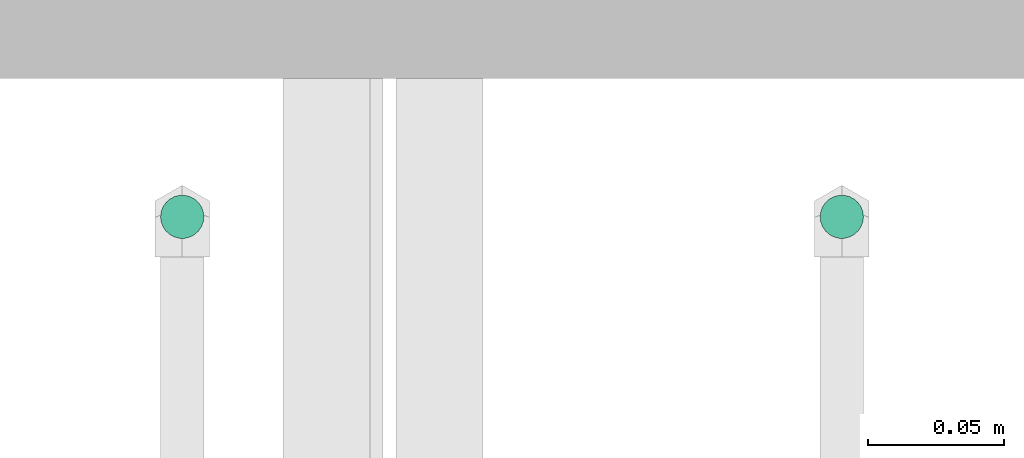
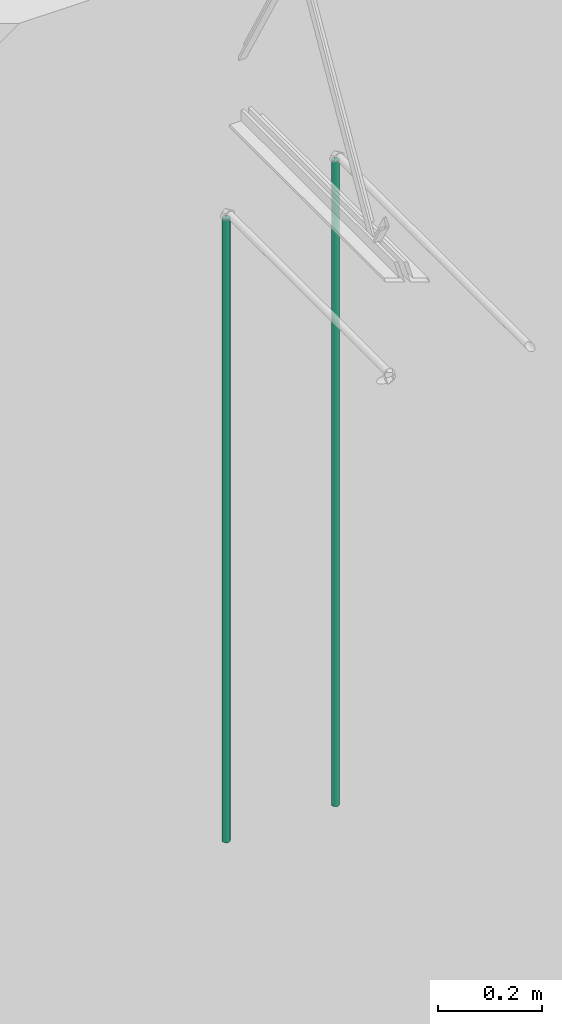
# One storey, part 9 of 31: 2 flow segments.
"""IFC2X3 building model written with IfcOpenShell, lengths in feet."""

from ifc_helpers import new_model, entity, si_unit, converted_unit, derived_unit, direction, frame, origin, origin_2d_with_axis, place, context, subcontext, project, spatial, circle, extrude, source, transform, mapped, type_object, type_shapes, element, save


model = new_model("IFC2X3")

# Units and contexts
model_context = context("Model", 3, precision=0.0001, world=origin(), true_north=direction((6.12303176911189e-17, 1.0)))
body_context = subcontext(model_context, "Body", "Model", "MODEL_VIEW")
ifc_project = project(units=[converted_unit("LENGTHUNIT", "FOOT", entity("IfcRatioMeasure", 0.3048), si_unit("LENGTHUNIT", "METRE"), dimensions=[1, 0, 0, 0, 0, 0, 0]), converted_unit("AREAUNIT", "SQUARE FOOT", entity("IfcRatioMeasure", 0.09290304), si_unit("AREAUNIT", "SQUARE_METRE"), dimensions=[2, 0, 0, 0, 0, 0, 0]), converted_unit("VOLUMEUNIT", "CUBIC FOOT", entity("IfcRatioMeasure", 0.028316846592), si_unit("VOLUMEUNIT", "CUBIC_METRE"), dimensions=[3, 0, 0, 0, 0, 0, 0]), converted_unit("PLANEANGLEUNIT", "DEGREE", entity("IfcRatioMeasure", 0.0174532925199433), si_unit("PLANEANGLEUNIT", "RADIAN"), dimensions=[0, 0, 0, 0, 0, 0, 0]), si_unit("MASSUNIT", "GRAM", prefix="KILO"), derived_unit("MASSDENSITYUNIT", [(si_unit("MASSUNIT", "GRAM", prefix="KILO"), 1), (si_unit("LENGTHUNIT", "METRE"), -3)]), si_unit("TIMEUNIT", "SECOND"), si_unit("FREQUENCYUNIT", "HERTZ"), si_unit("THERMODYNAMICTEMPERATUREUNIT", "DEGREE_CELSIUS"), derived_unit("THERMALTRANSMITTANCEUNIT", [(si_unit("MASSUNIT", "GRAM", prefix="KILO"), 1), (si_unit("THERMODYNAMICTEMPERATUREUNIT", "KELVIN"), -1), (si_unit("TIMEUNIT", "SECOND"), -3)]), derived_unit("VOLUMETRICFLOWRATEUNIT", [(si_unit("LENGTHUNIT", "METRE"), 3), (si_unit("TIMEUNIT", "SECOND"), -1)]), si_unit("ELECTRICCURRENTUNIT", "AMPERE"), si_unit("ELECTRICVOLTAGEUNIT", "VOLT"), si_unit("POWERUNIT", "WATT"), si_unit("FORCEUNIT", "NEWTON"), si_unit("ILLUMINANCEUNIT", "LUX"), si_unit("LUMINOUSFLUXUNIT", "LUMEN"), si_unit("LUMINOUSINTENSITYUNIT", "CANDELA"), derived_unit("USERDEFINED", [(si_unit("MASSUNIT", "GRAM", prefix="KILO"), -1), (si_unit("LENGTHUNIT", "METRE"), -2), (si_unit("TIMEUNIT", "SECOND"), 3), (si_unit("LUMINOUSFLUXUNIT", "LUMEN"), 1)]), derived_unit("LINEARVELOCITYUNIT", [(si_unit("LENGTHUNIT", "METRE"), 1), (si_unit("TIMEUNIT", "SECOND"), -1)]), si_unit("PRESSUREUNIT", "PASCAL"), derived_unit("USERDEFINED", [(si_unit("LENGTHUNIT", "METRE"), -2), (si_unit("MASSUNIT", "GRAM", prefix="KILO"), 1), (si_unit("TIMEUNIT", "SECOND"), -2)])], contexts=[model_context])

# Site, building, storey
site_placement = place(None, origin())
site = spatial("IfcSite", under=ifc_project, at=site_placement, CompositionType="ELEMENT")
building_placement = place(site_placement, origin())
building = spatial("IfcBuilding", under=site, at=building_placement, CompositionType="ELEMENT")
storey_placement = place(building_placement, frame((0.0, 0.0, 13.3333333333323)))
storey = spatial("IfcBuildingStorey", under=building, at=storey_placement, Name="Level 2", CompositionType="ELEMENT", Elevation=13.3333333333323)

# Flow segments
pipe_segment_type_1 = type_object("IfcPipeSegmentType", Name="Pipe Types:Standard", PredefinedType="NOTDEFINED")
shared_shape_1 = source(origin(), body_context, "Body", "SweptSolid", [
    extrude(circle(Radius=0.0260416666666667, at=origin_2d_with_axis()), frame((40.2660253422419, 6.09936739686864, 19.3333333333323), z_axis=(0.0, 0.0, 1.0), x_axis=(-1.0, 0.0, 0.0)), (0.0, 0.0, 1.0), 4.95166015625001),
])
type_shapes(pipe_segment_type_1, [shared_shape_1])
flow_segment_1_placement = place(building_placement, origin())
element("IfcFlowSegment", 1, at=flow_segment_1_placement, inside=storey, type_object=pipe_segment_type_1, Name="Pipe Types:Standard:Standard : Pipe Types:Standard", ObjectType="Standard : Pipe Types:Standard", context=body_context, shape_type="MappedRepresentation", body=[
    mapped(shared_shape_1, transform((0.0, 0.0, 0.0), scale=1.0)),
])
pipe_segment_type_2 = type_object("IfcPipeSegmentType", Name="Pipe Types:Standard", PredefinedType="NOTDEFINED")
shared_shape_2 = source(origin(), body_context, "Body", "SweptSolid", [
    extrude(circle(Radius=0.0260416666666667, at=origin_2d_with_axis()), frame((39.4724205095678, 6.09936739686864, 19.3333333333323), z_axis=(0.0, 0.0, 1.0), x_axis=(-1.0, 0.0, 0.0)), (0.0, 0.0, 1.0), 4.78499348958334),
])
type_shapes(pipe_segment_type_2, [shared_shape_2])
flow_segment_2_placement = place(building_placement, origin())
element("IfcFlowSegment", 2, at=flow_segment_2_placement, inside=storey, type_object=pipe_segment_type_2, Name="Pipe Types:Standard:Standard : Pipe Types:Standard", ObjectType="Standard : Pipe Types:Standard", context=body_context, shape_type="MappedRepresentation", body=[
    mapped(shared_shape_2, transform((0.0, 0.0, 0.0), scale=1.0)),
])

save(model, "model.ifc")
